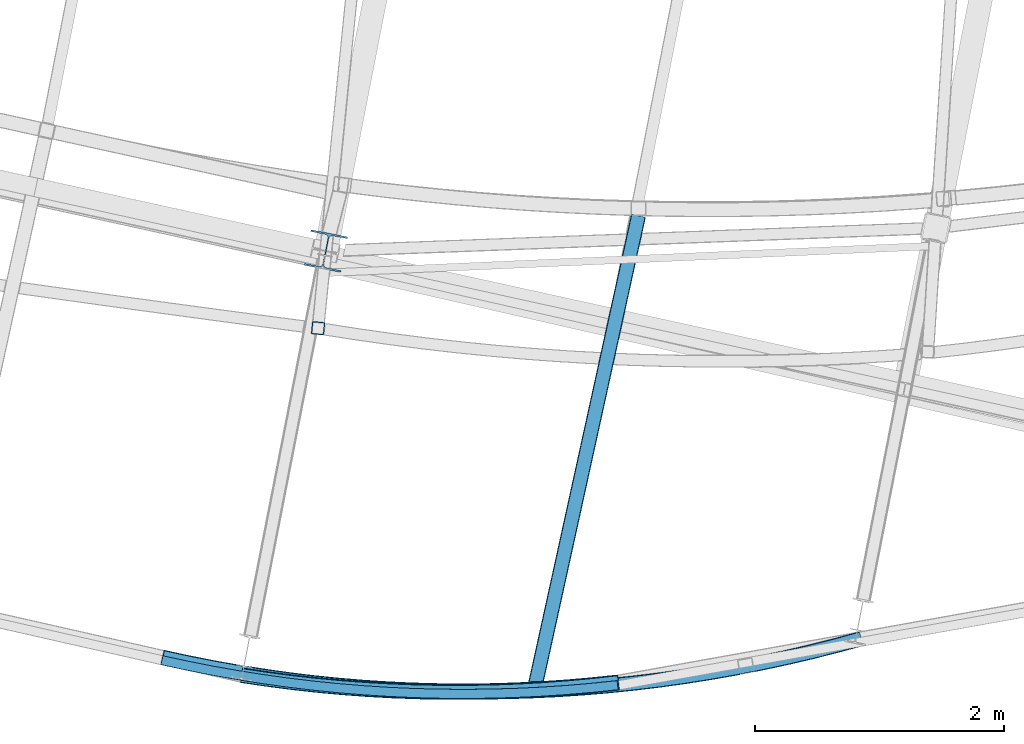
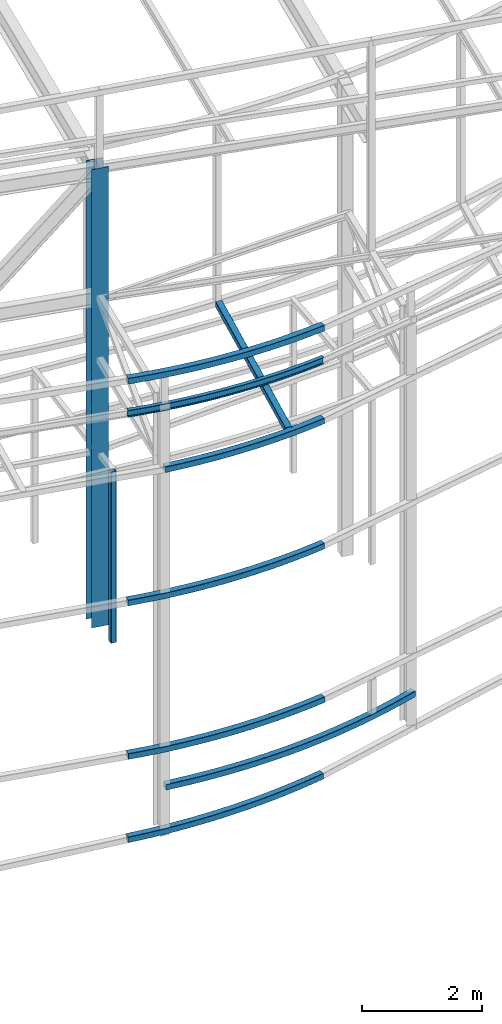
# One storey, part 50 of 215: 10 beams, 10 elements without a shape of their own.
"""IFC2X3 building model written with IfcOpenShell, lengths in millimetres."""

from ifc_helpers import new_model, entity, si_unit, frame, origin_with_axes, origin_2d_with_axis, place, context, subcontext, project, spatial, hollow_rectangle, i_section, extrude, material, type_object, element, aggregate, save


model = new_model("IFC2X3")

# Units and contexts
model_context = context("Model", 3, precision=1e-05, world=origin_with_axes())
body_context = subcontext(model_context, "Body", "Model", "MODEL_VIEW")
ifc_project = project(units=[si_unit("LENGTHUNIT", "METRE", prefix="MILLI"), si_unit("AREAUNIT", "SQUARE_METRE"), si_unit("VOLUMEUNIT", "CUBIC_METRE"), si_unit("MASSUNIT", "GRAM", prefix="KILO"), si_unit("TIMEUNIT", "SECOND"), si_unit("PLANEANGLEUNIT", "RADIAN"), si_unit("SOLIDANGLEUNIT", "STERADIAN"), si_unit("THERMODYNAMICTEMPERATUREUNIT", "DEGREE_CELSIUS"), si_unit("LUMINOUSINTENSITYUNIT", "LUMEN")], contexts=[model_context])

# Site, building, storey
site_placement = place(None, origin_with_axes())
site = spatial("IfcSite", under=ifc_project, at=site_placement, CompositionType="ELEMENT")
building_placement = place(site_placement, origin_with_axes())
building = spatial("IfcBuilding", under=site, at=building_placement, Name="Undefined", CompositionType="ELEMENT")
storey_placement = place(building_placement, origin_with_axes())
storey = spatial("IfcBuildingStorey", under=building, at=storey_placement, Name="Undefined", CompositionType="ELEMENT", Elevation=0.0)

# Assembly, beam
assembly_1_placement = place(storey_placement, origin_with_axes())
assembly_1 = element("IfcElementAssembly", 1, at=assembly_1_placement, inside=storey, Name="Steel Assembly", AssemblyPlace="NOTDEFINED", PredefinedType="RIGID_FRAME")
ifc_material = material(Name="STEEL/S275JR")
beam_type_1 = type_object("IfcBeamType", PredefinedType="NOTDEFINED")
beam_1_placement = place(assembly_1_placement, frame((74198.4979061616, 3155.27360858525, 6760.00000147429), z_axis=(-0.994954911339962, 0.10032310003428, 0.0), x_axis=(0.0, 0.0, -1.0)))
beam_1 = element("IfcBeam", 2, at=beam_1_placement, type_object=beam_type_1, material=ifc_material, Name="MONTANT", context=body_context, shape_type="SweptSolid", body=[
    extrude(hollow_rectangle(XDim=100.0, YDim=100.0, WallThickness=4.0, InnerFilletRadius=4.0, OuterFilletRadius=8.0, at=origin_2d_with_axis()), frame((3499.99999998675, 0.0, 0.0), z_axis=(-1.0, 0.0, 0.0), x_axis=(-6.93889390390723e-18, -1.0, -3.46944695195361e-18)), (0.0, 0.0, 1.0), 3500.0),
])
aggregate(assembly_1, [beam_1])

assembly_2_placement = place(storey_placement, origin_with_axes())
assembly_2 = element("IfcElementAssembly", 3, at=assembly_2_placement, inside=storey, Name="Steel Assembly", AssemblyPlace="NOTDEFINED", PredefinedType="RIGID_FRAME")
beam_type_2 = type_object("IfcBeamType", PredefinedType="NOTDEFINED")
beam_2_placement = place(assembly_2_placement, frame((76613.3376636165, 309.069122294794, 10572.1002245198), z_axis=(0.0214317899900027, 0.00561008699738245, 0.999754572533533), x_axis=(-0.998302752857527, 0.0542823149922532, 0.0210960639969891)))
beam_2 = element("IfcBeam", 4, at=beam_2_placement, type_object=beam_type_2, material=ifc_material, Name="LISSE", context=body_context, shape_type="SweptSolid", body=[
    entity("IfcRevolvedAreaSolid", entity("IfcRectangleHollowProfileDef", "AREA", None, entity("IfcAxis2Placement2D", entity("IfcCartesianPoint", [0.0, 0.0]), entity("IfcDirection", [1.0, 0.0])), 120.0, 120.0, 4.0, 4.0, 8.0), entity("IfcAxis2Placement3D", entity("IfcCartesianPoint", [3670.34880120994, -1.77083306410286e-14, -2.54681609219287e-14]), entity("IfcDirection", [-0.985829733044016, 0.167749031133909, 6.98606701609979e-18]), entity("IfcDirection", [-0.167749031133909, -0.985829733044016, 3.08921738907721e-19])), entity("IfcAxis1Placement", entity("IfcCartesianPoint", [10940.0, 0.0, 0.0]), entity("IfcDirection", [0.0, 1.0, 0.0])), 0.337091798441029),
])
aggregate(assembly_2, [beam_2])

assembly_3_placement = place(storey_placement, origin_with_axes())
assembly_3 = element("IfcElementAssembly", 5, at=assembly_3_placement, inside=storey, Name="Steel Assembly", AssemblyPlace="NOTDEFINED", PredefinedType="RIGID_FRAME")
beam_type_3 = type_object("IfcBeamType", PredefinedType="NOTDEFINED")
beam_3_placement = place(assembly_3_placement, frame((72954.0322384498, 509.130767148212, 2980.96223420893), z_axis=(0.0550280390271633, 0.998484809492933, -1.15190000058215e-05), x_axis=(0.998484809562204, -0.0550280389758723, 0.0)))
beam_3 = element("IfcBeam", 6, at=beam_3_placement, type_object=beam_type_3, material=ifc_material, Name="LISSE", context=body_context, shape_type="SweptSolid", body=[
    entity("IfcRevolvedAreaSolid", entity("IfcRectangleHollowProfileDef", "AREA", None, entity("IfcAxis2Placement2D", entity("IfcCartesianPoint", [0.0, 0.0]), entity("IfcDirection", [1.0, 0.0])), 120.0, 120.0, 5.0, 5.0, 10.0), entity("IfcAxis2Placement3D", entity("IfcCartesianPoint", [3666.20284411195, 4.54746962712139e-13, -9.09494701772928e-13]), entity("IfcDirection", [-0.985861957317995, -1.79474715534474e-22, -0.167559544977695]), entity("IfcDirection", [-6.93889390390723e-18, -1.0, -3.46944695195361e-18])), entity("IfcAxis1Placement", entity("IfcCartesianPoint", [0.0, 10940.0, 0.0]), entity("IfcDirection", [-1.0, 0.0, 0.0])), 0.336707385083592),
])
aggregate(assembly_3, [beam_3])

assembly_4_placement = place(storey_placement, origin_with_axes())
assembly_4 = element("IfcElementAssembly", 7, at=assembly_4_placement, inside=storey, Name="Steel Assembly", AssemblyPlace="NOTDEFINED", PredefinedType="RIGID_FRAME")
beam_4_placement = place(assembly_4_placement, frame((78565.2459067715, 660.080404475161, 2199.48935516225), z_axis=(0.0558284059879936, -0.998440221785266, 0.000559111999879666), x_axis=(-0.998440377555351, -0.0558283749751371, 7.08149999684266e-05)))
beam_4 = element("IfcBeam", 8, at=beam_4_placement, type_object=beam_type_3, material=ifc_material, Name="LISSE", context=body_context, shape_type="SweptSolid", body=[
    entity("IfcRevolvedAreaSolid", entity("IfcRectangleHollowProfileDef", "AREA", None, entity("IfcAxis2Placement2D", entity("IfcCartesianPoint", [0.0, 0.0]), entity("IfcDirection", [1.0, 0.0])), 120.0, 120.0, 5.0, 5.0, 10.0), entity("IfcAxis2Placement3D", entity("IfcCartesianPoint", [4965.09191548814, 0.0, 4.04901833347267e-13]), entity("IfcDirection", [-0.97617032208712, 2.3527812243717e-20, 0.217005765537069]), entity("IfcDirection", [-6.93889390390723e-18, -1.0, -3.46944695195361e-18])), entity("IfcAxis1Placement", entity("IfcCartesianPoint", [0.0, -11440.0, 0.0]), entity("IfcDirection", [1.0, 0.0, 0.0])), 0.437492182594547),
])
aggregate(assembly_4, [beam_4])

assembly_5_placement = place(storey_placement, origin_with_axes())
assembly_5 = element("IfcElementAssembly", 9, at=assembly_5_placement, inside=storey, Name="Steel Assembly", AssemblyPlace="NOTDEFINED", PredefinedType="RIGID_FRAME")
beam_5_placement = place(assembly_5_placement, frame((76773.2326993083, 4058.87072795125, 8706.00015386169), z_axis=(0.976698978906498, -0.214613849979456, -1.00000033844003e-09), x_axis=(-0.214613849979455, -0.976698978906498, 0.0)))
beam_5 = element("IfcBeam", 10, at=beam_5_placement, type_object=beam_type_3, material=ifc_material, Name="LISSE", context=body_context, shape_type="SweptSolid", body=[
    extrude(hollow_rectangle(XDim=120.0, YDim=120.0, WallThickness=5.0, InnerFilletRadius=5.0, OuterFilletRadius=10.0, at=origin_2d_with_axis()), frame((3865.34486358583, 1.81898940354586e-12, 0.0), z_axis=(-1.0, 0.0, 0.0), x_axis=(-6.93889390390723e-18, -1.0, -3.46944695195361e-18)), (0.0, 0.0, 1.0), 3865.3),
])
aggregate(assembly_5, [beam_5])

assembly_6_placement = place(storey_placement, origin_with_axes())
assembly_6 = element("IfcElementAssembly", 11, at=assembly_6_placement, inside=storey, Name="Steel Assembly", AssemblyPlace="NOTDEFINED", PredefinedType="RIGID_FRAME")
beam_6_placement = place(assembly_6_placement, frame((72948.1438215301, 509.955156888026, 1279.294855272), z_axis=(0.0549478849961666, 0.998486662930315, 0.00226138999984207), x_axis=(0.99770769297193, -0.0549943259984528, 0.0394332789988905)))
beam_6 = element("IfcBeam", 12, at=beam_6_placement, type_object=beam_type_3, material=ifc_material, Name="LISSE", context=body_context, shape_type="SweptSolid", body=[
    entity("IfcRevolvedAreaSolid", entity("IfcRectangleHollowProfileDef", "AREA", None, entity("IfcAxis2Placement2D", entity("IfcCartesianPoint", [0.0, 0.0]), entity("IfcDirection", [1.0, 0.0])), 120.0, 120.0, 5.0, 5.0, 10.0), entity("IfcAxis2Placement3D", entity("IfcCartesianPoint", [3653.97509701359, -2.52728220968929e-13, -2.54040661224263e-14]), entity("IfcDirection", [-0.985956778739499, 6.84144948151152e-18, -0.167000689991481]), entity("IfcDirection", [-6.93889390390723e-18, -1.0, -3.46944695195361e-18])), entity("IfcAxis1Placement", entity("IfcCartesianPoint", [0.0, 10940.0, 0.0]), entity("IfcDirection", [-1.0, 0.0, 0.0])), 0.335573700813267),
])
aggregate(assembly_6, [beam_6])

assembly_7_placement = place(storey_placement, origin_with_axes())
assembly_7 = element("IfcElementAssembly", 13, at=assembly_7_placement, inside=storey, Name="Steel Assembly", AssemblyPlace="NOTDEFINED", PredefinedType="RIGID_FRAME")
beam_7_placement = place(assembly_7_placement, frame((72950.5691978264, 509.952457071157, 6117.50422463395), z_axis=(0.0550280390271633, 0.998484809492933, -1.15190000058215e-05), x_axis=(0.998484809562204, -0.0550280389758723, 0.0)))
beam_7 = element("IfcBeam", 14, at=beam_7_placement, type_object=beam_type_3, material=ifc_material, Name="LISSE", context=body_context, shape_type="SweptSolid", body=[
    entity("IfcRevolvedAreaSolid", entity("IfcRectangleHollowProfileDef", "AREA", None, entity("IfcAxis2Placement2D", entity("IfcCartesianPoint", [0.0, 0.0]), entity("IfcDirection", [1.0, 0.0])), 120.0, 120.0, 5.0, 5.0, 10.0), entity("IfcAxis2Placement3D", entity("IfcCartesianPoint", [3666.20284411195, 4.54746962712139e-13, -9.09494701772928e-13]), entity("IfcDirection", [-0.985861957317995, -1.79474715534474e-22, -0.167559544977695]), entity("IfcDirection", [-6.93889390390723e-18, -1.0, -3.46944695195361e-18])), entity("IfcAxis1Placement", entity("IfcCartesianPoint", [0.0, 10940.0, 0.0]), entity("IfcDirection", [-1.0, 0.0, 0.0])), 0.336707385083797),
])
aggregate(assembly_7, [beam_7])

assembly_8_placement = place(storey_placement, origin_with_axes())
assembly_8 = element("IfcElementAssembly", 15, at=assembly_8_placement, inside=storey, Name="Steel Assembly", AssemblyPlace="NOTDEFINED", PredefinedType="RIGID_FRAME")
beam_8_placement = place(assembly_8_placement, frame((73584.4179800757, 364.875422985688, 8706.04125207339), z_axis=(0.0187578760003296, 0.999821859017394, 0.00209578600003632), x_axis=(0.99977260770609, -0.0187356049944922, -0.0101838099970059)))
beam_8 = element("IfcBeam", 16, at=beam_8_placement, type_object=beam_type_3, material=ifc_material, Name="LISSE", context=body_context, shape_type="SweptSolid", body=[
    entity("IfcRevolvedAreaSolid", entity("IfcRectangleHollowProfileDef", "AREA", None, entity("IfcAxis2Placement2D", entity("IfcCartesianPoint", [0.0, 0.0]), entity("IfcDirection", [1.0, 0.0])), 120.0, 120.0, 5.0, 5.0, 10.0), entity("IfcAxis2Placement3D", entity("IfcCartesianPoint", [3027.08630819478, -1.81373824586322e-12, 2.89223919238796e-15]), entity("IfcDirection", [-0.990383473891418, -1.65804194589543e-18, -0.138349465639615]), entity("IfcDirection", [-6.93889390390723e-18, -1.0, -3.46944695195361e-18])), entity("IfcAxis1Placement", entity("IfcCartesianPoint", [0.0, 10940.0, 0.0]), entity("IfcDirection", [-1.0, 0.0, 0.0])), 0.277589318025936),
])
aggregate(assembly_8, [beam_8])

assembly_9_placement = place(storey_placement, origin_with_axes())
assembly_9 = element("IfcElementAssembly", 17, at=assembly_9_placement, inside=storey, Name="Steel Assembly", AssemblyPlace="NOTDEFINED", PredefinedType="RIGID_FRAME")
beam_type_4 = type_object("IfcBeamType", Name="HEA300", PredefinedType="NOTDEFINED")
beam_9_placement = place(assembly_9_placement, frame((74260.9931895486, 3775.4395257211, 12621.5655527274), z_axis=(0.191859470081235, 0.981422408415534, 0.0), x_axis=(0.0, 0.0, -1.0)))
beam_9 = element("IfcBeam", 18, at=beam_9_placement, type_object=beam_type_4, material=ifc_material, Name="POTEAU", ObjectType="HEA300", context=body_context, shape_type="SweptSolid", body=[
    extrude(i_section(OverallWidth=300.0, OverallDepth=290.0, WebThickness=8.5, FlangeThickness=14.0, FilletRadius=27.0, at=origin_2d_with_axis()), frame((9361.56764280749, 0.0, 0.0), z_axis=(-1.0, 0.0, 0.0), x_axis=(-6.93889390390723e-18, -1.0, -3.46944695195361e-18)), (0.0, 0.0, 1.0), 9361.6),
])
aggregate(assembly_9, [beam_9])

assembly_10_placement = place(storey_placement, origin_with_axes())
assembly_10 = element("IfcElementAssembly", 19, at=assembly_10_placement, inside=storey, Name="Steel Assembly", AssemblyPlace="NOTDEFINED", PredefinedType="RIGID_FRAME")
beam_type_5 = type_object("IfcBeamType", Name="IPE140", PredefinedType="NOTDEFINED")
beam_10_placement = place(assembly_10_placement, frame((72941.9509965719, 487.105385996086, 9984.31118909536), z_axis=(-0.0201398730042802, 0.0010916540002324, -0.999796576212839), x_axis=(0.998300060227403, -0.0546825720124562, -0.0201694340045945)))
beam_10 = element("IfcBeam", 20, at=beam_10_placement, type_object=beam_type_5, material=ifc_material, Name="LISSE", ObjectType="IPE140", context=body_context, shape_type="SweptSolid", body=[
    entity("IfcRevolvedAreaSolid", entity("IfcIShapeProfileDef", "AREA", None, entity("IfcAxis2Placement2D", entity("IfcCartesianPoint", [0.0, 0.0]), entity("IfcDirection", [1.0, 0.0])), 73.0, 140.0, 4.699999809, 6.900000095, 7.0), entity("IfcAxis2Placement3D", entity("IfcCartesianPoint", [3668.45178150706, -9.3706742120536e-13, -1.27274988517385e-14]), entity("IfcDirection", [-0.985905534505847, 0.167302949856663, 3.4491725959672e-18]), entity("IfcDirection", [-0.167302949856663, -0.985905534505847, 4.11759626370473e-19])), entity("IfcAxis1Placement", entity("IfcCartesianPoint", [10963.5, 0.0, 0.0]), entity("IfcDirection", [0.0, 1.0, 0.0])), 0.336186846793663),
])
aggregate(assembly_10, [beam_10])

save(model, "model.ifc")
